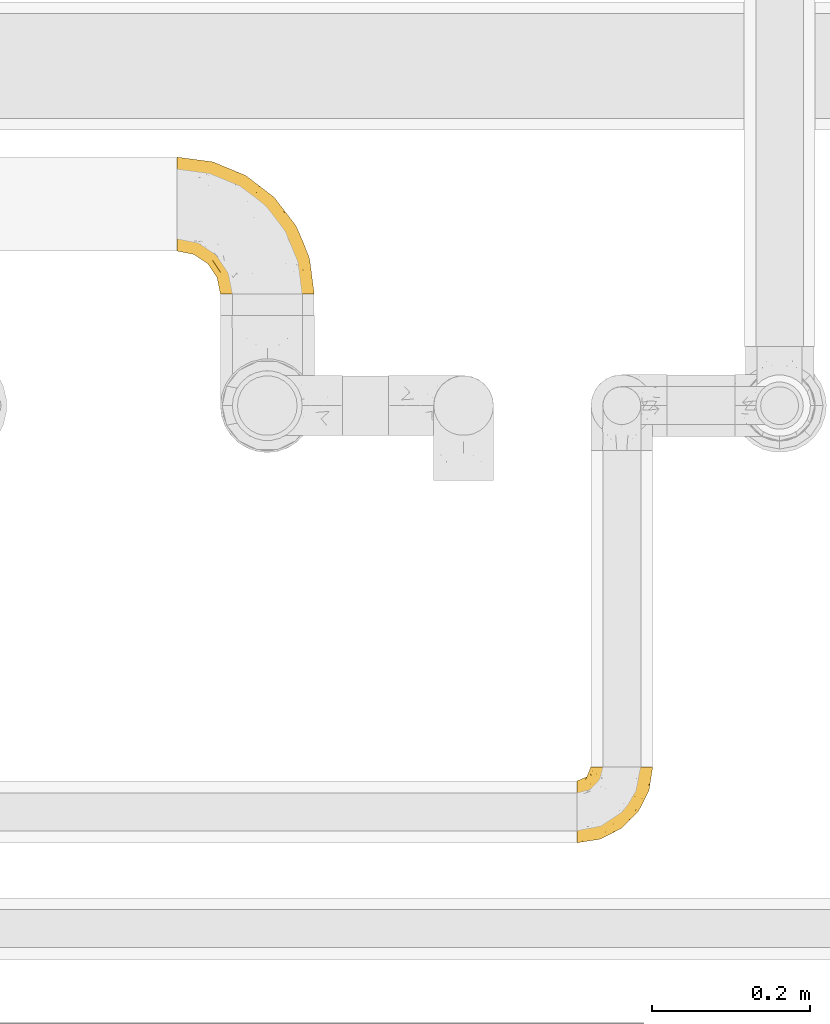
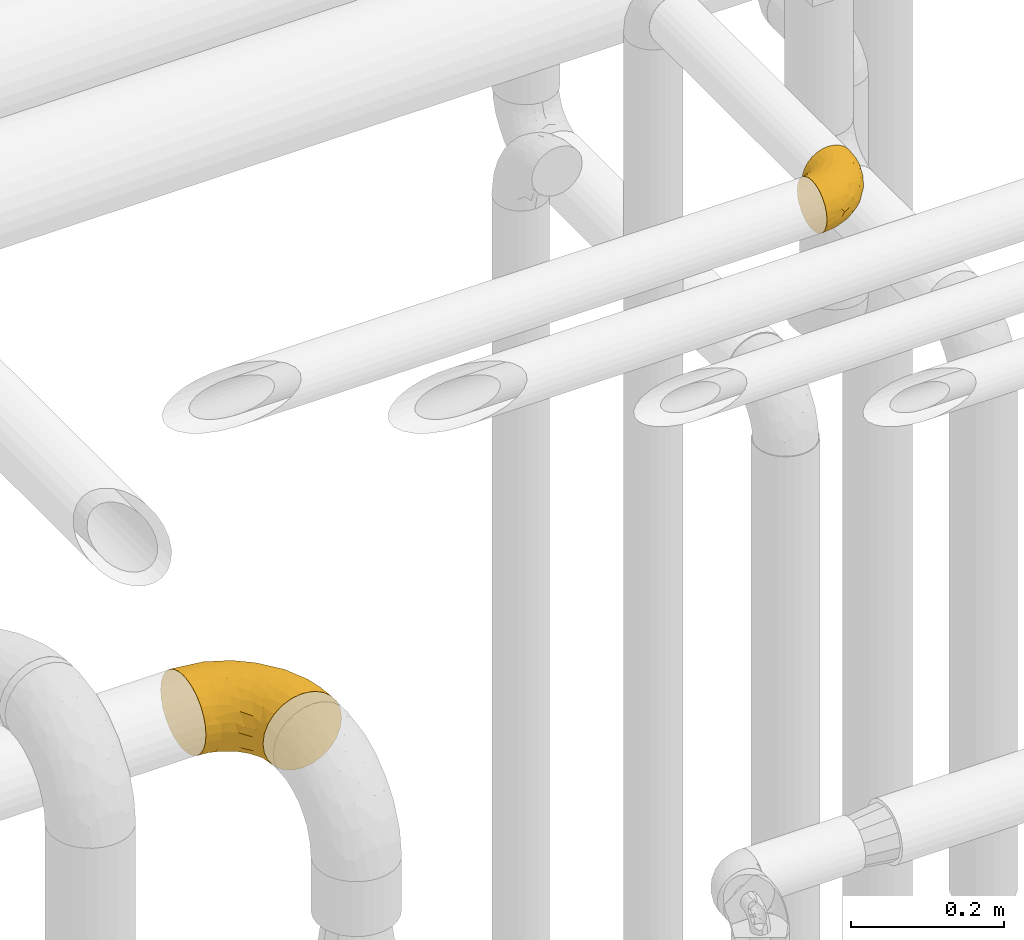
# One storey, part 473 of 827: 2 coverings.
"""IFC2X3 building model written with IfcOpenShell, lengths in millimetres."""

from ifc_helpers import new_model, entity, si_unit, converted_unit, derived_unit, direction, frame, origin, place, context, subcontext, project, spatial, faceted_brep, element, save


model = new_model("IFC2X3")

# Units and contexts
model_context = context("Model", 3, precision=0.01, world=origin(), true_north=direction((6.12303176911189e-17, 1.0)))
body_context = subcontext(model_context, "Body", "Model", "MODEL_VIEW")
ifc_project = project(units=[si_unit("LENGTHUNIT", "METRE", prefix="MILLI"), si_unit("AREAUNIT", "SQUARE_METRE"), si_unit("VOLUMEUNIT", "CUBIC_METRE"), converted_unit("PLANEANGLEUNIT", "DEGREE", entity("IfcRatioMeasure", 0.0174532925199433), si_unit("PLANEANGLEUNIT", "RADIAN"), dimensions=[0, 0, 0, 0, 0, 0, 0]), si_unit("MASSUNIT", "GRAM", prefix="KILO"), derived_unit("MASSDENSITYUNIT", [(si_unit("MASSUNIT", "GRAM", prefix="KILO"), 1), (si_unit("LENGTHUNIT", "METRE"), -3)]), derived_unit("MOMENTOFINERTIAUNIT", [(si_unit("LENGTHUNIT", "METRE"), 4)]), si_unit("TIMEUNIT", "SECOND"), si_unit("FREQUENCYUNIT", "HERTZ"), si_unit("THERMODYNAMICTEMPERATUREUNIT", "DEGREE_CELSIUS"), derived_unit("THERMALTRANSMITTANCEUNIT", [(si_unit("MASSUNIT", "GRAM", prefix="KILO"), 1), (si_unit("THERMODYNAMICTEMPERATUREUNIT", "KELVIN"), -1), (si_unit("TIMEUNIT", "SECOND"), -3)]), derived_unit("VOLUMETRICFLOWRATEUNIT", [(si_unit("LENGTHUNIT", "METRE"), 3), (si_unit("TIMEUNIT", "SECOND"), -1)]), derived_unit("MASSFLOWRATEUNIT", [(si_unit("MASSUNIT", "GRAM", prefix="KILO"), 1), (si_unit("TIMEUNIT", "SECOND"), -1)]), derived_unit("ROTATIONALFREQUENCYUNIT", [(si_unit("TIMEUNIT", "SECOND"), -1)]), si_unit("ELECTRICCURRENTUNIT", "AMPERE"), si_unit("ELECTRICVOLTAGEUNIT", "VOLT"), si_unit("POWERUNIT", "WATT"), si_unit("FORCEUNIT", "NEWTON", prefix="KILO"), si_unit("ILLUMINANCEUNIT", "LUX"), si_unit("LUMINOUSFLUXUNIT", "LUMEN"), si_unit("LUMINOUSINTENSITYUNIT", "CANDELA"), derived_unit("USERDEFINED", [(si_unit("MASSUNIT", "GRAM", prefix="KILO"), -1), (si_unit("LENGTHUNIT", "METRE"), -2), (si_unit("TIMEUNIT", "SECOND"), 3), (si_unit("LUMINOUSFLUXUNIT", "LUMEN"), 1)]), derived_unit("LINEARVELOCITYUNIT", [(si_unit("LENGTHUNIT", "METRE"), 1), (si_unit("TIMEUNIT", "SECOND"), -1)]), si_unit("PRESSUREUNIT", "PASCAL"), derived_unit("USERDEFINED", [(si_unit("LENGTHUNIT", "METRE"), -2), (si_unit("MASSUNIT", "GRAM", prefix="KILO"), 1), (si_unit("TIMEUNIT", "SECOND"), -2)]), derived_unit("LINEARFORCEUNIT", [(si_unit("MASSUNIT", "GRAM", prefix="KILO"), 1), (si_unit("LENGTHUNIT", "METRE"), 1), (si_unit("TIMEUNIT", "SECOND"), -2), (si_unit("LENGTHUNIT", "METRE"), -1)]), derived_unit("PLANARFORCEUNIT", [(si_unit("MASSUNIT", "GRAM", prefix="KILO"), 1), (si_unit("LENGTHUNIT", "METRE"), 1), (si_unit("TIMEUNIT", "SECOND"), -2), (si_unit("LENGTHUNIT", "METRE"), -2)])], contexts=[model_context])

# Site, building, storey
site_placement = place(None, origin())
site = spatial("IfcSite", under=ifc_project, at=site_placement, CompositionType="ELEMENT")
building_placement = place(site_placement, origin())
building = spatial("IfcBuilding", under=site, at=building_placement, CompositionType="ELEMENT")
storey_placement = place(building_placement, frame((0.0, 0.0, 28200.0)))
storey = spatial("IfcBuildingStorey", under=building, at=storey_placement, Name="08", CompositionType="ELEMENT", Elevation=28200.0)

# Coverings
covering_1_placement = place(storey_placement, frame((58533.79, 17639.5, 2038.95)))
element("IfcCovering", 1, at=covering_1_placement, inside=storey, Name=":ADSK_", ObjectType=":ADSK_", PredefinedType="INSULATION", context=body_context, shape_type="Brep", body=[
    faceted_brep([(1.6, 128.83, 119.0), (1.6, 141.39, 114.61), (1.6, 152.67, 107.52), (1.6, 162.08, 98.11), (1.6, 169.16, 86.83), (1.6, 173.56, 74.26), (1.6, 175.05, 61.05), (1.6, 173.55, 47.81), (1.6, 169.16, 35.25), (1.6, 162.07, 23.97), (1.6, 152.66, 14.56), (1.6, 141.38, 7.48), (1.6, 128.81, 3.08), (1.6, 115.6, 1.6), (1.6, 102.36, 3.09), (1.6, 89.8, 7.48), (1.6, 78.52, 14.57), (1.6, 69.11, 23.99), (1.6, 62.03, 35.26), (1.6, 57.63, 47.83), (1.6, 56.15, 61.05), (1.6, 57.64, 74.28), (1.6, 62.03, 86.84), (1.6, 69.12, 98.12), (1.6, 78.54, 107.53), (1.6, 89.81, 114.61), (1.6, 102.38, 119.01), (1.6, 115.6, 120.5), (58.17, 1.6, 45.66), (64.11, 1.6, 31.32), (73.56, 1.6, 19.01), (85.87, 1.6, 9.56), (100.21, 1.6, 3.62), (115.6, 1.6, 1.6), (130.98, 1.6, 3.62), (145.32, 1.6, 9.56), (157.63, 1.6, 19.01), (167.08, 1.6, 31.32), (173.02, 1.6, 45.66), (175.05, 1.6, 61.05), (173.02, 1.6, 76.43), (167.08, 1.6, 90.77), (157.63, 1.6, 103.08), (145.32, 1.6, 112.53), (130.98, 1.6, 118.47), (115.6, 1.6, 120.5), (100.21, 1.6, 118.47), (85.87, 1.6, 112.53), (73.56, 1.6, 103.08), (64.11, 1.6, 90.77), (58.17, 1.6, 76.43), (56.15, 1.6, 61.05), (160.93, 32.35, 95.74), (165.97, 43.24, 82.17), (151.16, 67.79, 93.88), (169.95, 39.06, 71.8), (169.14, 46.49, 61.05), (47.74, 143.21, 109.14), (81.62, 128.0, 108.65), (69.65, 144.51, 100.7), (137.09, 104.87, 79.94), (151.81, 88.32, 61.05), (124.24, 124.24, 61.05), (120.32, 70.72, 115.7), (136.76, 48.42, 112.92), (129.05, 74.22, 110.7), (127.83, 37.66, 117.93), (111.19, 61.68, 119.47), (73.49, 151.61, 89.21), (40.92, 162.2, 91.01), (154.8, 73.52, 83.0), (161.22, 66.93, 71.74), (148.51, 43.54, 106.1), (46.49, 169.14, 61.05), (43.55, 166.98, 79.17), (105.65, 137.86, 76.32), (75.81, 156.83, 73.8), (102.22, 103.08, 112.99), (111.05, 111.05, 104.29), (31.64, 122.98, 119.46), (61.68, 111.19, 119.47), (70.72, 120.32, 115.7), (93.82, 68.6, 120.5), (101.92, 52.71, 120.5), (110.02, 36.82, 120.5), (88.32, 151.81, 61.05), (34.61, 134.29, 115.97), (34.27, 155.8, 101.43), (130.32, 102.22, 94.14), (101.6, 130.43, 94.58), (135.16, 80.3, 104.07), (92.65, 92.65, 118.63), (68.6, 93.82, 120.5), (81.21, 81.21, 120.5), (16.21, 113.28, 120.5), (36.82, 110.02, 120.5), (52.71, 101.92, 120.5), (113.28, 16.21, 120.5), (49.51, 84.67, 117.67), (24.29, 87.66, 114.99), (33.37, 74.04, 109.18), (97.47, 21.09, 118.26), (92.13, 35.03, 117.87), (65.64, 52.93, 111.2), (63.0, 39.76, 103.41), (72.44, 34.91, 108.57), (54.52, 67.69, 112.76), (38.38, 44.31, 75.65), (46.09, 44.87, 89.98), (30.11, 54.18, 85.51), (22.47, 51.99, 61.05), (22.86, 53.35, 73.87), (82.06, 18.29, 111.26), (68.74, 23.44, 101.69), (56.57, 28.92, 88.74), (60.39, 13.79, 86.0), (55.21, 18.1, 74.52), (47.46, 32.62, 70.92), (51.99, 22.47, 61.05), (19.27, 100.59, 118.96), (66.98, 78.3, 119.01), (75.5, 62.67, 117.67), (15.03, 58.76, 82.93), (21.65, 64.93, 96.71), (38.96, 56.12, 96.25), (16.17, 75.28, 106.01), (36.61, 97.34, 119.26), (42.47, 64.0, 105.56), (40.17, 40.17, 61.05), (81.33, 38.41, 114.42), (89.72, 51.71, 119.14), (52.09, 52.67, 102.94), (62.98, 39.74, 18.7), (52.08, 52.66, 19.16), (65.65, 52.9, 10.9), (89.82, 27.75, 5.81), (89.72, 51.71, 2.95), (97.2, 38.57, 2.72), (38.35, 44.33, 46.46), (54.51, 67.68, 9.34), (68.6, 93.82, 1.6), (81.21, 81.21, 1.6), (66.99, 78.3, 3.08), (55.21, 18.1, 47.58), (24.29, 87.65, 7.11), (60.39, 13.78, 36.09), (16.17, 75.27, 16.09), (21.63, 64.92, 25.4), (97.47, 21.09, 3.83), (113.28, 16.21, 1.6), (75.5, 62.67, 4.42), (68.74, 23.43, 20.4), (47.46, 32.63, 51.15), (82.06, 18.29, 10.83), (42.47, 63.99, 16.53), (38.93, 56.13, 25.84), (22.84, 53.35, 48.24), (36.82, 110.02, 1.6), (52.71, 101.92, 1.6), (36.62, 97.32, 2.83), (16.21, 113.28, 1.6), (30.08, 54.19, 36.6), (15.02, 58.76, 39.17), (46.08, 44.88, 32.11), (56.57, 28.91, 33.35), (101.92, 52.71, 1.6), (49.52, 84.65, 4.42), (33.36, 74.03, 12.92), (19.28, 100.57, 3.14), (72.43, 34.93, 13.52), (93.82, 68.6, 1.6), (110.02, 36.82, 1.6), (81.33, 38.41, 7.67), (151.16, 67.79, 28.21), (160.93, 32.35, 26.35), (148.51, 43.54, 15.99), (136.76, 48.42, 9.17), (169.95, 39.06, 50.29), (165.97, 43.24, 39.92), (161.22, 66.93, 50.35), (111.19, 61.68, 2.62), (70.72, 120.32, 6.39), (31.66, 122.97, 2.63), (34.61, 134.28, 6.11), (111.05, 111.05, 17.8), (81.57, 128.03, 13.43), (101.58, 130.43, 27.5), (61.68, 111.19, 2.62), (92.65, 92.65, 3.46), (127.83, 37.66, 4.16), (154.8, 73.52, 39.09), (69.65, 144.5, 21.38), (34.27, 155.79, 20.65), (73.47, 151.61, 32.87), (32.52, 164.01, 31.06), (105.65, 137.86, 45.77), (137.09, 104.87, 42.15), (47.72, 143.2, 12.94), (129.05, 74.22, 11.39), (102.2, 103.12, 9.11), (43.54, 166.97, 42.91), (135.17, 80.3, 18.03), (130.32, 102.23, 27.95), (76.08, 155.79, 45.01), (120.32, 70.72, 6.39)], [[[0, 1, 2, 3, 4, 5, 6, 7, 8, 9, 10, 11, 12, 13, 14, 15, 16, 17, 18, 19, 20, 21, 22, 23, 24, 25, 26, 27]], [[28, 29, 30, 31, 32, 33, 34, 35, 36, 37, 38, 39, 40, 41, 42, 43, 44, 45, 46, 47, 48, 49, 50, 51]], [[52, 53, 54]], [[55, 39, 56]], [[57, 58, 59]], [[60, 61, 62]], [[63, 64, 65]], [[66, 63, 67]], [[59, 68, 69]], [[53, 70, 54]], [[41, 40, 53]], [[53, 71, 70]], [[72, 42, 52]], [[42, 41, 52]], [[73, 5, 74]], [[68, 75, 76]], [[43, 72, 64]], [[45, 44, 66]], [[58, 77, 78]], [[79, 80, 81]], [[67, 82, 83, 84]], [[75, 62, 85]], [[1, 0, 86]], [[2, 87, 3]], [[57, 87, 2]], [[42, 72, 43]], [[5, 4, 74]], [[2, 1, 57]], [[69, 3, 87]], [[5, 73, 6]], [[59, 87, 57]], [[66, 64, 63]], [[88, 89, 78]], [[54, 88, 90]], [[75, 60, 62]], [[91, 92, 93, 82]], [[79, 27, 94, 95]], [[76, 73, 74]], [[80, 95, 96, 92]], [[57, 1, 86]], [[56, 71, 55]], [[77, 91, 63]], [[80, 91, 81]], [[67, 91, 82]], [[71, 56, 61]], [[69, 4, 3]], [[74, 69, 68]], [[75, 89, 60]], [[80, 79, 95]], [[81, 57, 86]], [[76, 75, 85]], [[89, 68, 59]], [[58, 57, 81]], [[59, 58, 89]], [[90, 88, 78]], [[75, 68, 89]], [[70, 88, 54]], [[60, 89, 88]], [[77, 58, 81]], [[89, 58, 78]], [[91, 77, 81]], [[77, 63, 65]], [[78, 77, 65]], [[54, 90, 72]], [[91, 80, 92]], [[79, 81, 86]], [[86, 0, 79]], [[27, 79, 0]], [[66, 84, 97, 45]], [[91, 67, 63]], [[84, 66, 67]], [[64, 44, 43]], [[64, 66, 44]], [[65, 72, 90]], [[53, 52, 41]], [[72, 52, 54]], [[72, 65, 64]], [[65, 90, 78]], [[60, 71, 61]], [[55, 71, 53]], [[71, 60, 70]], [[88, 70, 60]], [[53, 40, 55]], [[39, 55, 40]], [[4, 69, 74]], [[59, 69, 87]], [[73, 76, 85]], [[68, 76, 74]], [[98, 99, 100]], [[84, 101, 97]], [[84, 83, 102]], [[97, 101, 46]], [[103, 104, 105]], [[47, 46, 101]], [[106, 98, 100]], [[107, 108, 109]], [[110, 107, 111]], [[112, 48, 47]], [[48, 113, 49]], [[113, 114, 115]], [[116, 51, 50]], [[115, 50, 49]], [[116, 117, 118]], [[119, 95, 94]], [[111, 107, 109]], [[93, 120, 121]], [[122, 123, 22]], [[121, 106, 103]], [[25, 24, 99]], [[114, 113, 104]], [[124, 109, 108]], [[25, 119, 26]], [[27, 26, 94]], [[112, 113, 48]], [[125, 123, 100]], [[24, 125, 99]], [[111, 20, 110]], [[109, 122, 111]], [[119, 94, 26]], [[99, 126, 119]], [[123, 124, 127]], [[117, 107, 128]], [[122, 22, 21]], [[129, 130, 121]], [[123, 23, 22]], [[92, 98, 120]], [[127, 106, 100]], [[23, 125, 24]], [[93, 121, 82]], [[119, 126, 95]], [[21, 20, 111]], [[123, 122, 109]], [[21, 111, 122]], [[107, 110, 128]], [[117, 128, 118]], [[107, 117, 108]], [[104, 108, 114]], [[124, 108, 131]], [[25, 99, 119]], [[96, 126, 98]], [[98, 92, 96]], [[123, 125, 23]], [[99, 125, 100]], [[103, 106, 131]], [[120, 106, 121]], [[83, 82, 130]], [[101, 102, 112]], [[130, 102, 83]], [[121, 130, 82]], [[102, 130, 129]], [[101, 112, 47]], [[112, 129, 105]], [[118, 51, 116]], [[108, 117, 114]], [[115, 116, 50]], [[114, 117, 116]], [[112, 102, 129]], [[102, 101, 84]], [[104, 103, 131]], [[129, 121, 103]], [[104, 131, 108]], [[105, 104, 113]], [[112, 105, 113]], [[103, 105, 129]], [[127, 124, 131]], [[123, 109, 124]], [[106, 127, 131]], [[123, 127, 100]], [[98, 126, 99]], [[95, 126, 96]], [[113, 115, 49]], [[116, 115, 114]], [[46, 45, 97]], [[92, 120, 93]], [[106, 120, 98]], [[132, 133, 134]], [[135, 136, 137]], [[110, 138, 128]], [[139, 134, 133]], [[140, 141, 142]], [[143, 51, 118]], [[16, 15, 144]], [[28, 145, 29]], [[146, 147, 17]], [[144, 146, 16]], [[31, 148, 32]], [[148, 149, 32]], [[139, 142, 150]], [[30, 29, 151]], [[152, 143, 118]], [[31, 30, 153]], [[139, 133, 154]], [[155, 154, 133]], [[110, 156, 138]], [[142, 141, 150]], [[20, 19, 156]], [[157, 158, 159]], [[14, 13, 160]], [[17, 16, 146]], [[161, 162, 147]], [[18, 162, 19]], [[152, 163, 164]], [[137, 136, 165]], [[144, 166, 167]], [[133, 163, 155]], [[144, 167, 146]], [[147, 18, 17]], [[29, 145, 151]], [[128, 138, 152]], [[160, 157, 168]], [[160, 168, 14]], [[14, 168, 15]], [[167, 166, 139]], [[151, 169, 153]], [[162, 156, 19]], [[141, 170, 150]], [[164, 163, 132]], [[147, 162, 18]], [[156, 162, 161]], [[156, 161, 138]], [[156, 110, 20]], [[163, 138, 161]], [[128, 152, 118]], [[155, 163, 161]], [[132, 163, 133]], [[159, 166, 144]], [[144, 15, 168]], [[166, 158, 140]], [[168, 159, 144]], [[147, 146, 167]], [[142, 139, 166]], [[134, 139, 150]], [[135, 31, 153]], [[136, 170, 165]], [[136, 150, 170]], [[148, 137, 171]], [[150, 136, 172]], [[151, 153, 30]], [[136, 135, 172]], [[163, 152, 138]], [[143, 28, 51]], [[152, 164, 143]], [[145, 143, 164]], [[171, 137, 165]], [[137, 148, 135]], [[31, 135, 148]], [[172, 135, 153]], [[150, 172, 134]], [[132, 169, 151]], [[169, 134, 172]], [[164, 132, 151]], [[134, 169, 132]], [[153, 169, 172]], [[161, 147, 155]], [[154, 147, 167]], [[147, 154, 155]], [[139, 154, 167]], [[157, 159, 168]], [[166, 159, 158]], [[143, 145, 28]], [[151, 145, 164]], [[149, 148, 171]], [[149, 33, 32]], [[140, 142, 166]], [[173, 174, 175]], [[35, 34, 176]], [[177, 178, 179]], [[180, 171, 165, 170]], [[181, 182, 183]], [[184, 185, 186]], [[187, 188, 140]], [[189, 33, 149, 171]], [[178, 190, 179]], [[34, 189, 176]], [[39, 38, 177]], [[191, 192, 193]], [[9, 8, 194]], [[174, 178, 37]], [[38, 37, 178]], [[35, 175, 36]], [[195, 62, 196]], [[180, 189, 171]], [[37, 36, 174]], [[183, 11, 197]], [[188, 170, 141, 140]], [[184, 198, 199]], [[8, 7, 200]], [[201, 184, 202]], [[13, 12, 182]], [[181, 185, 199]], [[183, 12, 11]], [[62, 195, 85]], [[202, 184, 186]], [[10, 197, 11]], [[199, 188, 181]], [[194, 8, 200]], [[203, 195, 193]], [[62, 61, 196]], [[197, 191, 185]], [[10, 192, 197]], [[7, 6, 73]], [[197, 192, 191]], [[192, 10, 9]], [[193, 192, 194]], [[7, 73, 200]], [[179, 61, 56]], [[203, 73, 85]], [[187, 140, 158, 157]], [[180, 188, 204]], [[179, 196, 61]], [[197, 181, 183]], [[181, 187, 182]], [[201, 173, 175]], [[203, 193, 200]], [[186, 191, 193]], [[197, 185, 181]], [[193, 195, 186]], [[196, 186, 195]], [[186, 196, 202]], [[190, 202, 196]], [[186, 185, 191]], [[199, 185, 184]], [[198, 184, 201]], [[188, 199, 204]], [[173, 201, 202]], [[175, 176, 198]], [[188, 180, 170]], [[189, 180, 204]], [[189, 204, 176]], [[189, 34, 33]], [[187, 157, 182]], [[188, 187, 181]], [[182, 157, 160, 13]], [[12, 183, 182]], [[198, 176, 204]], [[35, 176, 175]], [[175, 174, 36]], [[178, 174, 173]], [[199, 198, 204]], [[175, 198, 201]], [[177, 179, 56]], [[178, 173, 190]], [[202, 190, 173]], [[196, 179, 190]], [[39, 177, 56]], [[38, 178, 177]], [[193, 194, 200]], [[9, 194, 192]], [[73, 203, 200]], [[85, 195, 203]]]),
])
covering_2_placement = place(storey_placement, frame((59039.54, 16944.95, 3159.25)))
element("IfcCovering", 2, at=covering_2_placement, inside=storey, Name=":ADSK_", ObjectType=":ADSK_", PredefinedType="INSULATION", context=body_context, shape_type="Brep", body=[
    faceted_brep([(58.6, 97.75, 79.9), (67.31, 97.75, 78.91), (75.59, 97.75, 76.02), (83.01, 97.75, 71.35), (89.21, 97.75, 65.15), (93.87, 97.75, 57.73), (96.76, 97.75, 49.45), (97.75, 97.75, 40.75), (96.76, 97.75, 32.03), (93.87, 97.75, 23.75), (89.2, 97.75, 16.33), (83.0, 97.75, 10.13), (75.58, 97.75, 5.47), (67.3, 97.75, 2.58), (58.6, 97.75, 1.6), (55.4, 97.75, 1.96), (49.88, 97.75, 2.58), (45.74, 97.75, 4.03), (41.6, 97.75, 5.48), (34.18, 97.75, 10.14), (27.98, 97.75, 16.34), (23.32, 97.75, 23.76), (20.43, 97.75, 32.04), (19.45, 97.75, 40.75), (20.43, 97.75, 49.46), (23.33, 97.75, 57.74), (27.99, 97.75, 65.16), (34.19, 97.75, 71.36), (41.61, 97.75, 76.02), (49.89, 97.75, 78.91), (55.4, 97.75, 79.54), (1.6, 68.43, 13.06), (1.6, 60.32, 6.84), (1.6, 50.88, 2.93), (1.6, 47.16, 2.44), (1.6, 43.95, 2.02), (1.6, 40.75, 1.6), (1.6, 30.61, 2.93), (1.6, 21.17, 6.84), (1.6, 13.06, 13.06), (1.6, 6.84, 21.17), (1.6, 2.93, 30.61), (1.6, 1.6, 40.75), (1.6, 2.93, 50.88), (1.6, 6.84, 60.32), (1.6, 13.06, 68.43), (1.6, 21.17, 74.65), (1.6, 30.61, 78.56), (1.6, 40.75, 79.9), (1.6, 47.16, 79.05), (1.6, 50.88, 78.56), (1.6, 60.32, 74.65), (1.6, 68.43, 68.43), (1.6, 74.65, 60.32), (1.6, 78.56, 50.88), (1.6, 79.9, 40.75), (1.6, 78.56, 30.61), (1.6, 74.65, 21.17), (68.75, 30.59, 40.75), (79.38, 41.23, 40.75), (67.95, 31.39, 53.99), (58.11, 19.96, 40.75), (31.31, 6.3, 40.75), (25.48, 5.21, 47.49), (20.85, 4.64, 40.75), (48.28, 15.42, 51.52), (38.29, 15.6, 61.86), (24.38, 6.88, 54.43), (18.7, 10.45, 63.37), (63.4, 80.79, 79.25), (43.9, 39.87, 77.04), (21.15, 25.91, 75.79), (41.26, 28.57, 72.61), (20.94, 35.0, 78.93), (24.69, 18.15, 70.12), (84.73, 74.57, 66.7), (79.29, 80.38, 72.7), (75.09, 59.65, 70.21), (55.53, 59.36, 78.8), (54.26, 75.93, 79.9), (51.17, 71.31, 79.9), (48.08, 66.69, 79.9), (44.99, 62.06, 79.9), (41.9, 57.44, 79.9), (59.1, 46.63, 74.44), (93.12, 74.83, 52.47), (38.11, 45.67, 79.33), (37.28, 54.35, 79.9), (32.65, 51.26, 79.9), (28.03, 48.17, 79.9), (23.41, 45.08, 79.9), (86.26, 54.03, 48.94), (84.36, 58.15, 58.78), (90.84, 80.8, 60.43), (94.7, 78.49, 40.75), (62.67, 31.82, 62.02), (76.37, 43.52, 57.53), (57.88, 94.17, 79.9), (57.17, 90.6, 79.9), (55.75, 83.46, 79.9), (74.1, 47.16, 64.12), (68.09, 64.11, 75.76), (72.38, 81.54, 76.65), (61.34, 38.43, 68.92), (48.69, 25.45, 66.73), (44.71, 13.13, 40.75), (93.04, 68.03, 40.75), (15.88, 43.59, 79.9), (12.31, 42.88, 79.9), (8.74, 42.17, 79.9), (86.21, 54.63, 40.75), (7.55, 73.05, 63.86), (12.14, 69.6, 69.15), (11.84, 51.66, 78.65), (9.55, 63.89, 72.98), (10.89, 57.82, 76.47), (17.57, 59.13, 76.82), (19.53, 52.25, 79.05), (25.5, 54.86, 79.09), (7.5, 79.38, 51.28), (12.73, 82.07, 51.03), (14.22, 85.12, 40.75), (8.19, 82.63, 40.75), (18.5, 89.2, 49.93), (20.38, 86.06, 58.53), (27.96, 81.78, 69.86), (22.53, 81.63, 65.19), (25.05, 76.19, 70.75), (51.05, 90.86, 79.25), (49.37, 85.89, 79.11), (6.49, 76.5, 57.89), (21.79, 92.32, 55.93), (37.29, 70.11, 78.06), (28.49, 69.83, 75.39), (33.82, 65.67, 78.16), (18.63, 76.0, 66.62), (21.37, 68.84, 73.14), (33.2, 91.37, 71.07), (42.33, 76.37, 78.32), (34.77, 83.17, 73.93), (42.81, 85.98, 77.25), (48.27, 79.95, 79.26), (17.49, 81.01, 60.3), (16.71, 91.15, 40.75), (26.81, 88.52, 65.72), (31.65, 75.86, 74.5), (12.9, 77.41, 60.62), (16.9, 64.86, 73.96), (23.37, 60.69, 77.3), (28.95, 62.7, 77.83), (6.49, 76.5, 23.6), (10.35, 73.85, 17.57), (57.88, 94.17, 1.6), (57.17, 90.6, 1.6), (55.75, 83.46, 1.6), (18.5, 89.2, 31.57), (20.37, 86.06, 22.97), (21.79, 92.32, 25.57), (26.8, 88.52, 15.78), (15.88, 43.59, 1.6), (8.74, 42.17, 1.6), (5.17, 41.46, 1.6), (12.14, 69.6, 12.34), (16.74, 64.84, 7.57), (10.0, 64.5, 8.85), (18.6, 52.81, 2.63), (17.57, 59.13, 4.67), (25.3, 54.5, 2.36), (23.41, 45.08, 1.6), (11.84, 51.66, 2.84), (48.27, 79.95, 2.24), (51.17, 71.31, 1.6), (42.31, 76.38, 3.18), (25.03, 76.18, 10.74), (18.73, 76.44, 15.18), (22.25, 81.43, 16.42), (7.5, 79.38, 30.21), (20.15, 70.71, 9.98), (12.73, 82.07, 30.46), (33.19, 91.37, 10.43), (27.5, 81.89, 12.05), (42.79, 85.98, 4.24), (34.75, 83.17, 7.56), (37.29, 70.11, 3.43), (49.36, 85.9, 2.38), (54.26, 75.93, 1.6), (28.95, 62.7, 3.66), (22.98, 61.23, 4.45), (31.63, 75.83, 6.98), (28.42, 69.82, 6.12), (10.01, 58.44, 5.38), (17.3, 81.13, 21.58), (48.08, 66.69, 1.6), (12.9, 77.41, 20.87), (33.78, 65.71, 3.35), (37.28, 54.35, 1.6), (41.9, 57.44, 1.6), (44.99, 62.06, 1.6), (28.03, 48.17, 1.6), (32.65, 51.26, 1.6), (38.11, 45.67, 2.16), (24.7, 18.15, 11.37), (21.15, 25.91, 5.7), (41.27, 28.58, 8.88), (61.33, 38.43, 12.57), (59.09, 46.64, 7.04), (75.08, 59.66, 11.27), (74.09, 47.16, 17.36), (55.53, 59.36, 2.69), (20.94, 35.0, 2.56), (25.48, 5.21, 34.0), (24.38, 6.88, 27.06), (43.89, 39.88, 4.45), (68.08, 64.12, 5.73), (18.7, 10.45, 18.12), (38.29, 15.6, 19.63), (67.95, 31.39, 27.49), (62.66, 31.82, 19.46), (63.4, 80.8, 2.24), (93.12, 74.83, 29.01), (84.73, 74.57, 14.78), (86.25, 54.02, 32.55), (79.28, 80.38, 8.78), (48.28, 15.42, 29.98), (76.37, 43.52, 23.95), (84.35, 58.15, 22.7), (90.83, 80.8, 21.05), (48.7, 25.47, 14.75), (72.37, 81.54, 4.84)], [[[0, 1, 2, 3, 4, 5, 6, 7, 8, 9, 10, 11, 12, 13, 14, 15, 16, 17, 18, 19, 20, 21, 22, 23, 24, 25, 26, 27, 28, 29, 30]], [[31, 32, 33, 34, 35, 36, 37, 38, 39, 40, 41, 42, 43, 44, 45, 46, 47, 48, 49, 50, 51, 52, 53, 54, 55, 56, 57]], [[58, 59, 60, 61]], [[62, 63, 64]], [[65, 66, 67]], [[67, 66, 68]], [[69, 1, 0]], [[70, 71, 72]], [[44, 43, 67]], [[47, 71, 73]], [[45, 74, 46]], [[68, 45, 44]], [[75, 76, 77]], [[76, 3, 2]], [[78, 79, 80, 81, 82, 83]], [[48, 47, 73]], [[70, 72, 84]], [[5, 85, 6]], [[86, 83, 87, 88, 89, 90]], [[91, 85, 92]], [[76, 75, 3]], [[71, 46, 74]], [[85, 5, 93]], [[45, 68, 74]], [[5, 4, 93]], [[85, 94, 6]], [[86, 78, 83]], [[60, 95, 65]], [[96, 95, 60]], [[75, 4, 3]], [[69, 0, 97, 98, 99, 79]], [[75, 77, 100]], [[43, 64, 63]], [[101, 102, 69]], [[101, 76, 102]], [[46, 71, 47]], [[95, 103, 104]], [[92, 85, 93]], [[63, 105, 65]], [[92, 75, 100]], [[91, 106, 85]], [[84, 78, 70]], [[67, 68, 44]], [[65, 67, 63]], [[65, 61, 60]], [[4, 75, 93]], [[92, 93, 75]], [[102, 76, 2]], [[77, 76, 101]], [[84, 77, 101]], [[77, 103, 100]], [[72, 71, 74]], [[70, 86, 73]], [[104, 74, 66]], [[84, 72, 103]], [[70, 73, 71]], [[73, 90, 107, 108, 109, 48]], [[79, 78, 69]], [[101, 69, 78]], [[91, 92, 96]], [[91, 59, 110, 106]], [[2, 1, 102]], [[69, 102, 1]], [[94, 85, 106]], [[94, 7, 6]], [[74, 68, 66]], [[43, 42, 64]], [[43, 63, 67]], [[73, 86, 90]], [[78, 86, 70]], [[95, 100, 103]], [[96, 92, 100]], [[104, 103, 72]], [[65, 95, 66]], [[74, 104, 72]], [[66, 95, 104]], [[95, 96, 100]], [[91, 96, 60]], [[77, 84, 103]], [[78, 84, 101]], [[60, 59, 91]], [[105, 63, 62]], [[105, 61, 65]], [[111, 52, 112]], [[107, 90, 113]], [[114, 115, 116]], [[50, 107, 113]], [[117, 118, 116]], [[54, 119, 55]], [[97, 0, 30, 29, 98]], [[113, 115, 51]], [[120, 121, 122]], [[123, 120, 124]], [[125, 126, 127]], [[128, 28, 129]], [[130, 54, 53]], [[25, 24, 131]], [[132, 133, 134]], [[135, 112, 136]], [[137, 27, 26]], [[121, 120, 123]], [[138, 139, 132]], [[129, 140, 141]], [[135, 126, 142]], [[27, 140, 28]], [[27, 137, 140]], [[49, 48, 109, 108, 107, 50]], [[23, 143, 121, 123]], [[25, 131, 144]], [[26, 25, 144]], [[128, 98, 29]], [[125, 127, 145]], [[146, 130, 111]], [[137, 144, 139]], [[139, 138, 140]], [[116, 147, 114]], [[123, 124, 131]], [[116, 118, 148]], [[134, 83, 82]], [[129, 79, 99]], [[54, 130, 119]], [[141, 79, 129]], [[122, 55, 119]], [[120, 146, 142]], [[117, 113, 90]], [[50, 113, 51]], [[127, 133, 145]], [[147, 136, 112]], [[136, 133, 127]], [[24, 23, 123]], [[118, 117, 89]], [[149, 87, 134]], [[144, 131, 124]], [[24, 123, 131]], [[128, 129, 99]], [[28, 140, 129]], [[144, 137, 26]], [[140, 137, 139]], [[81, 138, 132]], [[138, 80, 141]], [[89, 88, 87, 118]], [[115, 117, 116]], [[140, 138, 141]], [[148, 118, 149]], [[136, 148, 149]], [[147, 116, 148]], [[133, 136, 149]], [[127, 126, 135]], [[136, 147, 148]], [[114, 112, 52]], [[112, 114, 147]], [[51, 114, 52]], [[51, 115, 114]], [[117, 115, 113]], [[117, 90, 89]], [[134, 133, 149]], [[145, 133, 132]], [[132, 139, 145]], [[125, 139, 144]], [[139, 125, 145]], [[126, 144, 124]], [[144, 126, 125]], [[142, 126, 124]], [[120, 142, 124]], [[142, 146, 135]], [[112, 135, 146]], [[136, 127, 135]], [[118, 87, 149]], [[82, 81, 132]], [[111, 130, 53]], [[119, 146, 120]], [[146, 119, 130]], [[122, 119, 120]], [[52, 111, 53]], [[146, 111, 112]], [[134, 82, 132]], [[83, 134, 87]], [[98, 128, 99]], [[80, 138, 81]], [[80, 79, 141]], [[28, 128, 29]], [[150, 151, 57]], [[15, 14, 152, 153, 154, 16]], [[121, 143, 23, 155]], [[150, 57, 56]], [[156, 157, 158]], [[35, 34, 33, 159, 160, 161, 36]], [[162, 31, 57]], [[163, 164, 162]], [[165, 166, 167]], [[155, 23, 22]], [[168, 159, 169]], [[170, 171, 172]], [[173, 174, 175]], [[55, 122, 176]], [[177, 174, 173]], [[22, 157, 155]], [[178, 121, 155]], [[169, 33, 32]], [[20, 19, 179]], [[21, 20, 158]], [[158, 180, 175]], [[181, 182, 179]], [[172, 183, 182]], [[122, 121, 178]], [[181, 19, 18]], [[184, 185, 170]], [[17, 154, 184]], [[186, 187, 177]], [[187, 186, 167]], [[179, 158, 20]], [[21, 157, 22]], [[175, 180, 173]], [[188, 189, 173]], [[164, 166, 190]], [[185, 184, 154]], [[181, 172, 182]], [[156, 191, 178]], [[192, 183, 172]], [[178, 176, 122]], [[193, 150, 176]], [[33, 169, 159]], [[190, 169, 32]], [[189, 194, 186]], [[180, 188, 173]], [[167, 166, 187]], [[166, 164, 163]], [[195, 194, 196]], [[158, 157, 21]], [[155, 157, 156]], [[178, 155, 156]], [[181, 18, 184]], [[17, 16, 154]], [[181, 179, 19]], [[158, 179, 182]], [[170, 181, 184]], [[196, 194, 197]], [[31, 190, 32]], [[165, 190, 166]], [[190, 31, 164]], [[31, 162, 164]], [[177, 163, 162]], [[187, 166, 163]], [[151, 174, 177]], [[177, 173, 189]], [[177, 187, 163]], [[195, 167, 186]], [[165, 198, 168]], [[165, 168, 169]], [[167, 198, 165]], [[190, 165, 169]], [[167, 195, 199, 198]], [[151, 177, 162]], [[175, 191, 156]], [[191, 174, 193]], [[158, 175, 156]], [[174, 191, 175]], [[178, 191, 193]], [[158, 182, 180]], [[188, 182, 183]], [[182, 188, 180]], [[183, 194, 189]], [[183, 189, 188]], [[177, 189, 186]], [[194, 183, 197]], [[176, 150, 56]], [[151, 150, 193]], [[176, 56, 55]], [[193, 176, 178]], [[174, 151, 193]], [[57, 151, 162]], [[183, 192, 197]], [[194, 195, 186]], [[171, 192, 172]], [[172, 181, 170]], [[170, 185, 171]], [[184, 18, 17]], [[200, 168, 198, 199, 195, 196]], [[201, 202, 203]], [[204, 203, 205]], [[204, 206, 207]], [[208, 196, 197, 192, 171, 185]], [[209, 36, 161, 160, 159, 168]], [[202, 38, 37]], [[201, 38, 202]], [[210, 41, 211]], [[200, 208, 212]], [[205, 208, 213]], [[214, 211, 40]], [[40, 211, 41]], [[214, 201, 215]], [[58, 61, 216, 59]], [[201, 39, 38]], [[207, 217, 204]], [[213, 208, 218]], [[218, 185, 154, 153, 152, 14]], [[14, 13, 218]], [[9, 8, 219]], [[10, 220, 11]], [[221, 106, 110, 59]], [[219, 8, 94]], [[220, 222, 11]], [[223, 211, 215]], [[221, 216, 224]], [[225, 219, 221]], [[10, 9, 226]], [[213, 222, 206]], [[226, 9, 219]], [[106, 219, 94]], [[212, 202, 209]], [[201, 203, 227]], [[226, 225, 220]], [[207, 206, 220]], [[214, 40, 39]], [[11, 222, 12]], [[12, 222, 228]], [[41, 210, 64]], [[223, 105, 210]], [[223, 215, 217]], [[105, 62, 210]], [[206, 222, 220]], [[228, 222, 213]], [[207, 220, 225]], [[205, 206, 204]], [[225, 226, 219]], [[220, 10, 226]], [[209, 202, 37]], [[203, 202, 212]], [[205, 203, 212]], [[204, 217, 227]], [[36, 209, 37]], [[209, 168, 200]], [[218, 13, 228]], [[208, 185, 218]], [[106, 221, 219]], [[221, 59, 216]], [[218, 228, 213]], [[13, 12, 228]], [[8, 7, 94]], [[201, 214, 39]], [[211, 214, 215]], [[64, 210, 62]], [[64, 42, 41]], [[223, 210, 211]], [[208, 200, 196]], [[209, 200, 212]], [[225, 224, 207]], [[207, 224, 217]], [[223, 217, 216]], [[204, 227, 203]], [[217, 215, 227]], [[201, 227, 215]], [[221, 224, 225]], [[217, 224, 216]], [[208, 205, 212]], [[206, 205, 213]], [[216, 61, 223]], [[223, 61, 105]]]),
])

save(model, "model.ifc")
